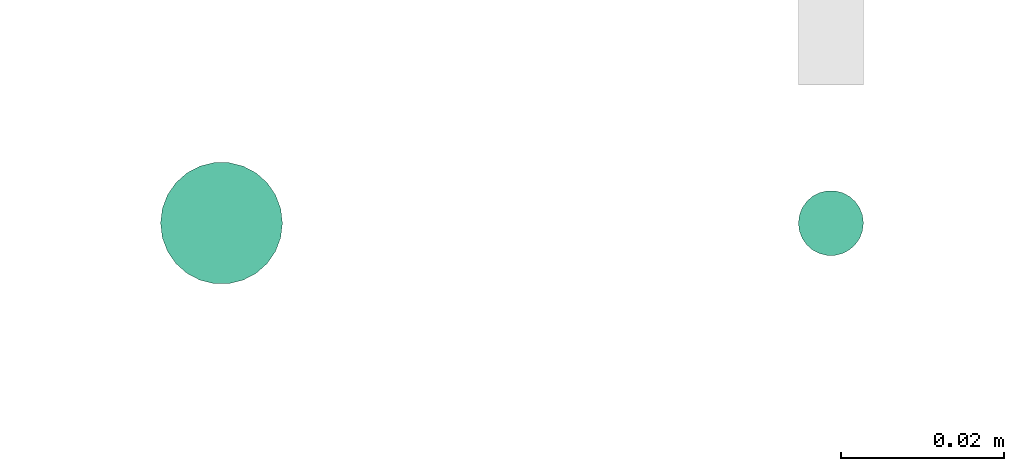
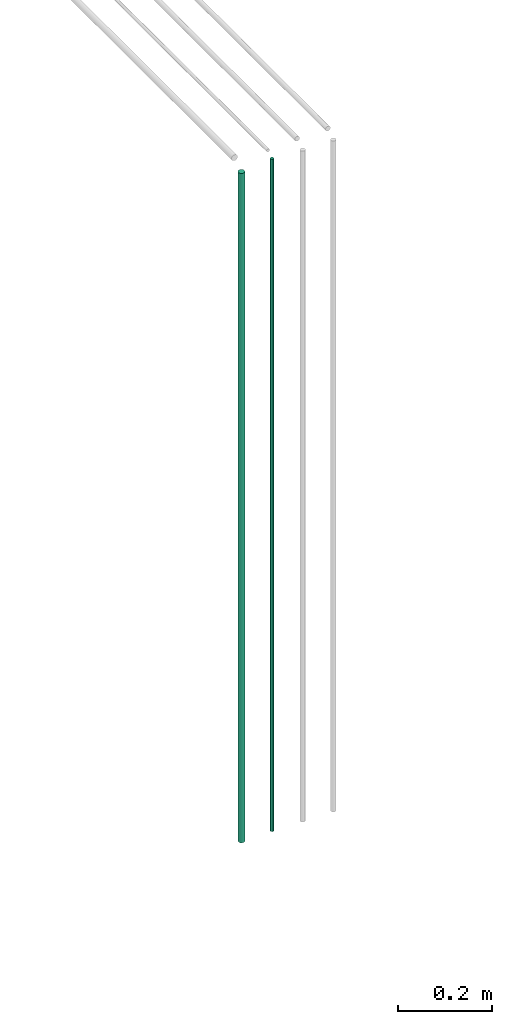
# One storey, part 14 of 65: 2 flow segments.
"""IFC2X3 building model written with IfcOpenShell, lengths in millimetres."""

from ifc_helpers import new_model, entity, si_unit, converted_unit, derived_unit, direction, frame, origin, origin_2d_with_axis, place, context, subcontext, project, spatial, circle, extrude, type_object, element, save


model = new_model("IFC2X3")

# Units and contexts
model_context = context("Model", 3, precision=0.01, world=origin(), true_north=direction((6.12303176911189e-17, 1.0)))
body_context = subcontext(model_context, "Body", "Model", "MODEL_VIEW")
ifc_project = project(units=[si_unit("LENGTHUNIT", "METRE", prefix="MILLI"), si_unit("AREAUNIT", "SQUARE_METRE"), si_unit("VOLUMEUNIT", "CUBIC_METRE"), converted_unit("PLANEANGLEUNIT", "DEGREE", entity("IfcRatioMeasure", 0.0174532925199433), si_unit("PLANEANGLEUNIT", "RADIAN"), dimensions=[0, 0, 0, 0, 0, 0, 0]), si_unit("MASSUNIT", "GRAM", prefix="KILO"), derived_unit("MASSDENSITYUNIT", [(si_unit("MASSUNIT", "GRAM", prefix="KILO"), 1), (si_unit("LENGTHUNIT", "METRE"), -3)]), derived_unit("MOMENTOFINERTIAUNIT", [(si_unit("LENGTHUNIT", "METRE"), 4)]), si_unit("TIMEUNIT", "SECOND"), si_unit("FREQUENCYUNIT", "HERTZ"), si_unit("THERMODYNAMICTEMPERATUREUNIT", "DEGREE_CELSIUS"), derived_unit("THERMALTRANSMITTANCEUNIT", [(si_unit("MASSUNIT", "GRAM", prefix="KILO"), 1), (si_unit("THERMODYNAMICTEMPERATUREUNIT", "KELVIN"), -1), (si_unit("TIMEUNIT", "SECOND"), -3)]), derived_unit("VOLUMETRICFLOWRATEUNIT", [(si_unit("LENGTHUNIT", "METRE"), 3), (si_unit("TIMEUNIT", "SECOND"), -1)]), derived_unit("MASSFLOWRATEUNIT", [(si_unit("MASSUNIT", "GRAM", prefix="KILO"), 1), (si_unit("TIMEUNIT", "SECOND"), -1)]), derived_unit("ROTATIONALFREQUENCYUNIT", [(si_unit("TIMEUNIT", "SECOND"), -1)]), si_unit("ELECTRICCURRENTUNIT", "AMPERE"), si_unit("ELECTRICVOLTAGEUNIT", "VOLT"), si_unit("POWERUNIT", "WATT"), si_unit("FORCEUNIT", "NEWTON", prefix="KILO"), si_unit("ILLUMINANCEUNIT", "LUX"), si_unit("LUMINOUSFLUXUNIT", "LUMEN"), si_unit("LUMINOUSINTENSITYUNIT", "CANDELA"), derived_unit("USERDEFINED", [(si_unit("MASSUNIT", "GRAM", prefix="KILO"), -1), (si_unit("LENGTHUNIT", "METRE"), -2), (si_unit("TIMEUNIT", "SECOND"), 3), (si_unit("LUMINOUSFLUXUNIT", "LUMEN"), 1)]), derived_unit("LINEARVELOCITYUNIT", [(si_unit("LENGTHUNIT", "METRE"), 1), (si_unit("TIMEUNIT", "SECOND"), -1)]), si_unit("PRESSUREUNIT", "PASCAL"), derived_unit("USERDEFINED", [(si_unit("LENGTHUNIT", "METRE"), -2), (si_unit("MASSUNIT", "GRAM", prefix="KILO"), 1), (si_unit("TIMEUNIT", "SECOND"), -2)]), derived_unit("LINEARFORCEUNIT", [(si_unit("MASSUNIT", "GRAM", prefix="KILO"), 1), (si_unit("LENGTHUNIT", "METRE"), 1), (si_unit("TIMEUNIT", "SECOND"), -2), (si_unit("LENGTHUNIT", "METRE"), -1)]), derived_unit("PLANARFORCEUNIT", [(si_unit("MASSUNIT", "GRAM", prefix="KILO"), 1), (si_unit("LENGTHUNIT", "METRE"), 1), (si_unit("TIMEUNIT", "SECOND"), -2), (si_unit("LENGTHUNIT", "METRE"), -2)])], contexts=[model_context])

# Site, building, storey
site_placement = place(None, frame((0.0, -0.00077364408347762, 0.0)))
site = spatial("IfcSite", under=ifc_project, at=site_placement, CompositionType="ELEMENT")
building_placement = place(site_placement, origin())
building = spatial("IfcBuilding", under=site, at=building_placement, CompositionType="ELEMENT")
storey_placement = place(building_placement, frame((0.0, 0.0, 19800.0)))
storey = spatial("IfcBuildingStorey", under=building, at=storey_placement, CompositionType="ELEMENT", Elevation=19800.0)

# Flow segments
pipe_segment_type = type_object("IfcPipeSegmentType", PredefinedType="NOTDEFINED")
flow_segment_1_placement = place(storey_placement, frame((64210.0323269755, 762.460170480084, 1400.0)))
element("IfcFlowSegment", 1, at=flow_segment_1_placement, inside=storey, type_object=pipe_segment_type, context=body_context, shape_type="SweptSolid", body=[
    extrude(circle(Radius=7.5, at=origin_2d_with_axis()), frame((9.09527223591419, 9.09527223591609, 0.0), z_axis=(0.0, 0.0, 1.0), x_axis=(-1.0, 0.0, 0.0)), (0.0, 0.0, 1.0), 1732.0),
])
flow_segment_2_placement = place(storey_placement, frame((64288.5323269755, 765.960170480084, 1400.0)))
element("IfcFlowSegment", 2, at=flow_segment_2_placement, inside=storey, type_object=pipe_segment_type, context=body_context, shape_type="SweptSolid", body=[
    extrude(circle(Radius=4.0, at=origin_2d_with_axis()), frame((5.59527223591499, 5.59527223591607, 0.0), z_axis=(0.0, 0.0, 1.0), x_axis=(-1.0, 0.0, 0.0)), (0.0, 0.0, 1.0), 1740.0),
])

save(model, "model.ifc")
